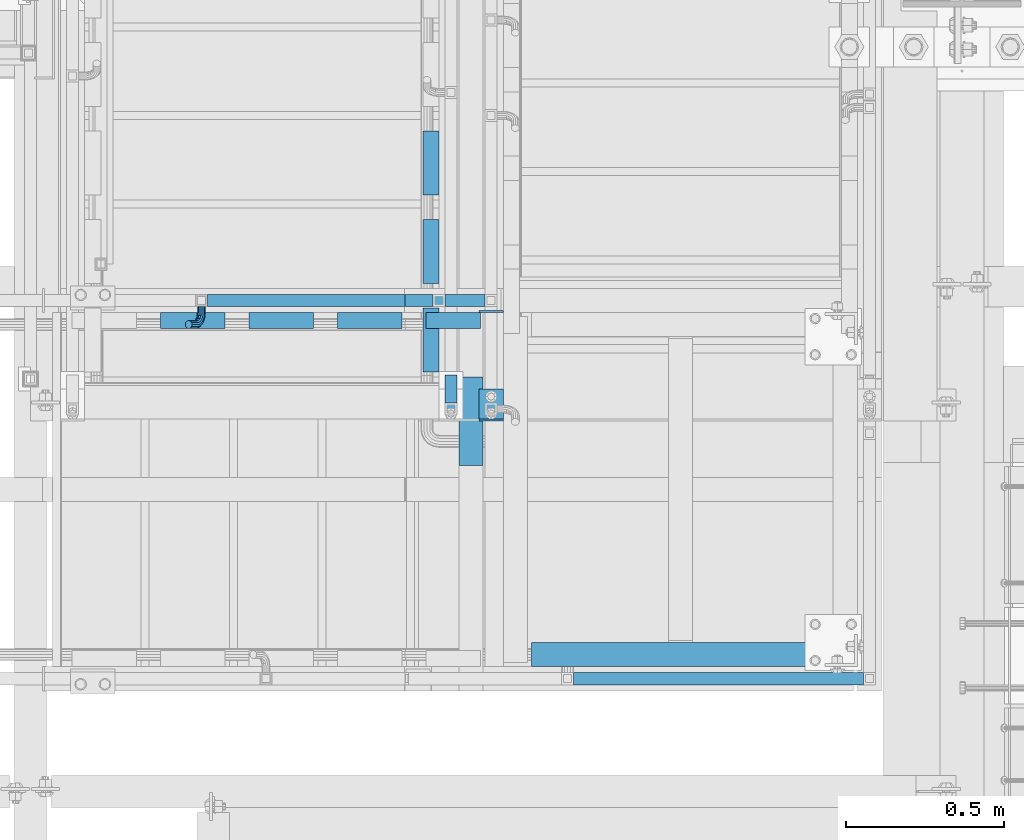
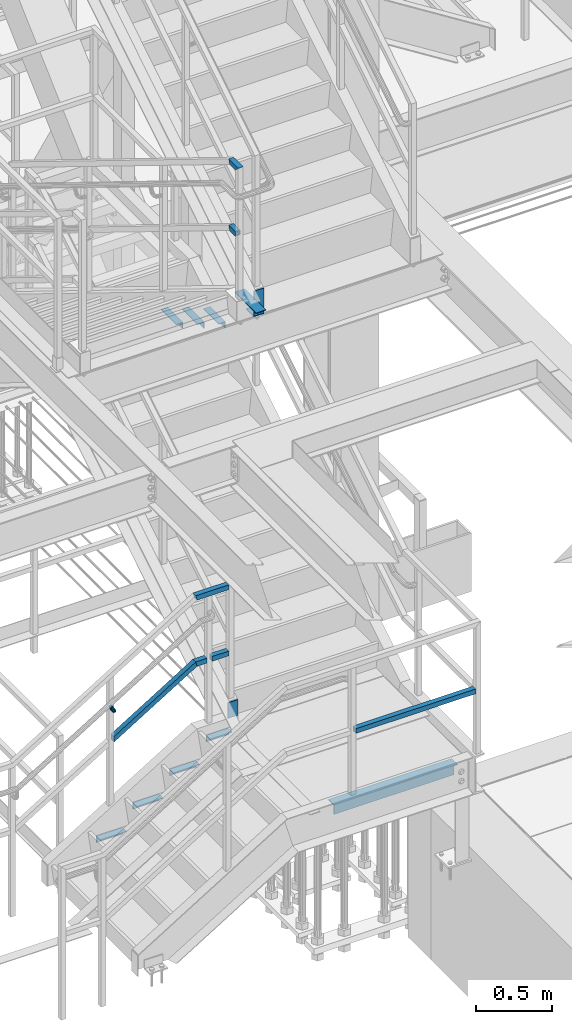
# One storey, part 2076 of 3843: 18 beams, 2 members, 8 elements without a shape of their own.
"""IFC2X3 building model written with IfcOpenShell, lengths in millimetres."""

from ifc_helpers import new_model, si_unit, frame, origin_with_axes, place, context, subcontext, project, spatial, faceted_brep, material, type_object, element, aggregate, save


model = new_model("IFC2X3")

# Units and contexts
model_context = context("Model", 3, precision=1e-05, world=origin_with_axes())
body_context = subcontext(model_context, "Body", "Model", "MODEL_VIEW")
ifc_project = project(units=[si_unit("LENGTHUNIT", "METRE", prefix="MILLI"), si_unit("AREAUNIT", "SQUARE_METRE"), si_unit("VOLUMEUNIT", "CUBIC_METRE"), si_unit("MASSUNIT", "GRAM", prefix="KILO"), si_unit("TIMEUNIT", "SECOND"), si_unit("PLANEANGLEUNIT", "RADIAN"), si_unit("SOLIDANGLEUNIT", "STERADIAN"), si_unit("THERMODYNAMICTEMPERATUREUNIT", "DEGREE_CELSIUS"), si_unit("LUMINOUSINTENSITYUNIT", "LUMEN")], contexts=[model_context])

# Site, building, storey
site_placement = place(None, origin_with_axes())
site = spatial("IfcSite", under=ifc_project, at=site_placement, CompositionType="ELEMENT")
building_placement = place(site_placement, origin_with_axes())
building = spatial("IfcBuilding", under=site, at=building_placement, Name="Undefined", CompositionType="ELEMENT")
storey_placement = place(building_placement, origin_with_axes())
storey = spatial("IfcBuildingStorey", under=building, at=storey_placement, Name="Undefined", CompositionType="ELEMENT", Elevation=0.0)

# Assembly, beams
assembly_1_placement = place(storey_placement, origin_with_axes())
assembly_1 = element("IfcElementAssembly", 1, at=assembly_1_placement, inside=storey, Name="RAIL", AssemblyPlace="NOTDEFINED", PredefinedType="RIGID_FRAME")
ifc_material_1 = material()
beam_type_1 = type_object("IfcBeamType", Name="HSS1-1/2X1-1/2X1/4", PredefinedType="NOTDEFINED")
beam_1_placement = place(assembly_1_placement, frame((54317.9, 18961.0999971442, 35483.7999969276), z_axis=(0.0, 0.0, 1.0), x_axis=(0.0, -1.0, 0.0)))
beam_1 = element("IfcBeam", 2, at=beam_1_placement, type_object=beam_type_1, material=ifc_material_1, Name="RAIL", ObjectType="HSS1-1/2X1-1/2X1/4", context=body_context, shape_type="Brep", body=[
    faceted_brep([(3.59463564452017, 12.6999993300014, -12.6999993299978), (3.59463564452017, -12.6999993300014, -12.6999993299978), (82.5500000532629, -12.6999993300014, -12.6999993299978), (82.5500000532629, 12.6999993300014, -12.6999993299978), (-3.59463560431323, -12.6999993300014, 12.6999993299978), (82.5500000532629, -12.6999993300014, 12.6999993299978), (-3.59463560431323, 12.6999993300014, 12.6999993299978), (82.5500000532629, 12.6999993300014, 12.6999993299978), (5.39195352466777, 19.0499992350015, -19.0499992350015), (-5.39195348444628, 19.0499992350015, 19.0499992350015), (82.5500000532629, 19.0499992350015, 19.0499992350015), (82.5500000532629, 19.0499992350015, -19.0499992350015), (-5.39195348444628, -19.0499992350015, 19.0499992350015), (82.5500000532629, -19.0499999999993, 19.0499992350015), (5.39195352466777, -19.0499992350015, -19.0499992350015), (82.5500000532629, -19.0499992350015, -19.0499992350015)], [[[0, 1, 2, 3]], [[1, 4, 5, 2]], [[4, 6, 7, 5]], [[6, 0, 3, 7]], [[8, 9, 10, 11]], [[9, 12, 13, 10]], [[12, 14, 15, 13]], [[14, 8, 11, 15]], [[13, 15, 11, 10], [5, 7, 3, 2]], [[14, 12, 9, 8], [6, 4, 1, 0]]]),
])
beam_2_placement = place(assembly_1_placement, frame((54317.9, 18859.4999999946, 36017.1999969276), z_axis=(0.0, 0.0, -1.0), x_axis=(0.0, 1.0, 0.0)))
beam_2 = element("IfcBeam", 3, at=beam_2_placement, type_object=beam_type_1, material=ifc_material_1, Name="RAIL", ObjectType="HSS1-1/2X1-1/2X1/4", context=body_context, shape_type="Brep", body=[
    faceted_brep([(-12.6999993309546, 12.6999993299978, -12.6999993299978), (-12.6999993309546, -12.6999993299978, -12.6999993299978), (105.194632755753, -12.6999993299978, -12.6999993299978), (105.194632755753, 12.6999993299978, -12.6999993299978), (12.6999993290483, -12.6999993299978, 12.6999993299978), (98.0053615143879, -12.6999993299978, 12.6999993299978), (12.6999993290483, 12.6999993299978, 12.6999993299978), (98.0053615143879, 12.6999993299978, 12.6999993299978), (-19.0499992359546, 19.0499992350015, -19.0499992350015), (19.0499992350015, 19.0499992350015, 19.0499992350015), (96.2080436361175, 19.0499992350015, 19.0499992350015), (106.991950634023, 19.0499992350015, -19.0499992350015), (19.0499992350015, -19.0499992350015, 19.0499992350015), (96.2080436361175, -19.0499992350015, 19.0499992350015), (-19.0499992359546, -19.0499992350015, -19.0499992350015), (106.991950634023, -19.0499992350015, -19.0499992350015)], [[[0, 1, 2, 3]], [[1, 4, 5, 2]], [[4, 6, 7, 5]], [[6, 0, 3, 7]], [[8, 9, 10, 11]], [[9, 12, 13, 10]], [[12, 14, 15, 13]], [[14, 8, 11, 15]], [[13, 15, 11, 10], [5, 7, 3, 2]], [[14, 12, 9, 8], [6, 4, 1, 0]]]),
])
aggregate(assembly_1, [beam_1, beam_2])

assembly_2_placement = place(storey_placement, origin_with_axes())
assembly_2 = element("IfcElementAssembly", 4, at=assembly_2_placement, inside=storey, Name="RAIL", AssemblyPlace="NOTDEFINED", PredefinedType="RIGID_FRAME")
beam_3_placement = place(assembly_2_placement, frame((54279.7999999953, 19202.4000001452, 31873.0923070972), z_axis=(0.0, 0.0, 1.0), x_axis=(-1.0, 0.0, 0.0)))
beam_3 = element("IfcBeam", 5, at=beam_3_placement, type_object=beam_type_1, material=ifc_material_1, Name="RAIL", ObjectType="HSS1-1/2X1-1/2X1/4", context=body_context, shape_type="Brep", body=[
    faceted_brep([(19.0499992350015, -19.0499992350015, -19.0499992350015), (19.0499992350015, -19.0499992350015, 19.0499992350015), (19.0499992350015, 19.0499992350015, 19.0499992350015), (19.0499992350015, 19.0499992350015, -19.0499992350015), (19.0499992350015, 12.6999993299978, 12.6999993299978), (19.0499992350015, -12.6999993299978, 12.6999993299978), (19.0499992350015, -12.6999993299978, -12.6999993299978), (19.0499992350015, 12.6999993299978, -12.6999993299978), (96.2080466457774, 19.0499992350015, -19.0499992350015), (96.2080466457774, -19.0499992350015, -19.0499992350015), (106.991953643679, -19.0499992350015, 19.0499992350015), (106.991953643679, 19.0499992350015, 19.0499992350015), (105.194635765409, -12.6999993300014, 12.6999993300014), (105.194635765409, 12.6999993300014, 12.6999993300014), (98.0053645240478, 12.6999993300014, -12.6999993300014), (98.0053645240478, -12.6999993300014, -12.6999993300014)], [[[0, 1, 2, 3], [4, 5, 6, 7]], [[8, 9, 0, 3]], [[9, 10, 1, 0]], [[10, 11, 2, 1]], [[11, 8, 3, 2]], [[10, 9, 8, 11], [12, 13, 14, 15]], [[13, 12, 5, 4]], [[14, 13, 4, 7]], [[15, 14, 7, 6]], [[12, 15, 6, 5]]]),
])
beam_4_placement = place(assembly_2_placement, frame((54444.9000000417, 19202.4000001452, 31873.0923070972), z_axis=(0.0, 0.0, 1.0), x_axis=(-1.0, 0.0, 0.0)))
beam_4 = element("IfcBeam", 6, at=beam_4_placement, type_object=beam_type_1, material=ifc_material_1, Name="RAIL", ObjectType="HSS1-1/2X1-1/2X1/4", context=body_context, shape_type="Brep", body=[
    faceted_brep([(19.0499992350015, -19.0499992350015, -19.0499992350015), (19.0499992350015, -19.0499992350015, 19.0499992350015), (19.0499992350015, 19.0499992350015, 19.0499992350015), (19.0499992350015, 19.0499992350015, -19.0499992350015), (19.0499992350015, 12.6999993299978, 12.6999993299978), (19.0499992350015, -12.6999993299978, 12.6999993299978), (19.0499992350015, -12.6999993299978, -12.6999993299978), (19.0499992350015, 12.6999993299978, -12.6999993299978), (146.049999950203, 19.0499992350015, -19.0499992350015), (146.049999950203, -19.0499992350015, -19.0499992350015), (146.049999950203, -19.0499992350015, 19.0499992350015), (146.049999950203, 19.0499992350015, 19.0499992350015), (146.049999950203, -12.6999993299978, 12.6999993299978), (146.049999950203, 12.6999993299978, 12.6999993299978), (146.049999950203, 12.6999993299978, -12.6999993299978), (146.049999950203, -12.6999993299978, -12.6999993299978)], [[[0, 1, 2, 3], [4, 5, 6, 7]], [[8, 9, 0, 3]], [[9, 10, 1, 0]], [[10, 11, 2, 1]], [[11, 8, 3, 2]], [[10, 9, 8, 11], [12, 13, 14, 15]], [[13, 12, 5, 4]], [[14, 13, 4, 7]], [[15, 14, 7, 6]], [[12, 15, 6, 5]]]),
])
beam_5_placement = place(assembly_2_placement, frame((54057.5499999936, 19202.4000001452, 32406.4923070972), z_axis=(0.0, 0.0, -1.0), x_axis=(1.0, 0.0, 0.0)))
beam_5 = element("IfcBeam", 7, at=beam_5_placement, type_object=beam_type_1, material=ifc_material_1, Name="RAIL", ObjectType="HSS1-1/2X1-1/2X1/4", context=body_context, shape_type="Brep", body=[
    faceted_brep([(368.300000006377, -19.0499998546729, 19.0499992350015), (368.300000006377, -19.0499992350015, -19.0499992350015), (368.300000006377, 19.0499992350015, -19.0499992350015), (368.300000006377, 19.0499992350015, 19.0499992350015), (368.300000006377, -12.6999993300014, 12.6999993300014), (368.300000006377, 12.6999993300014, 12.6999993300014), (368.300000006377, 12.6999993300014, -12.6999993300014), (368.300000006377, -12.6999993300014, -12.6999993300014), (115.258045902359, 19.0499992350015, -19.0499992350015), (126.041952911473, 19.0499992350015, 19.0499992350015), (115.258045902359, -19.0499992350015, -19.0499992350015), (126.041952911473, -19.0499992350015, 19.0499992350015), (117.0553637825, 12.6999993300014, -12.6999993300014), (124.24463503134, 12.6999993300014, 12.6999993300014), (124.24463503134, -12.6999993300014, 12.6999993300014), (117.0553637825, -12.6999993300014, -12.6999993300014)], [[[0, 1, 2, 3], [4, 5, 6, 7]], [[8, 9, 3, 2]], [[10, 8, 2, 1]], [[11, 10, 1, 0]], [[9, 11, 0, 3]], [[8, 10, 11, 9], [12, 13, 14, 15]], [[15, 14, 4, 7]], [[12, 15, 7, 6]], [[13, 12, 6, 5]], [[14, 13, 5, 4]]]),
])

# Assembly, beam
assembly_3_placement = place(storey_placement, origin_with_axes())
assembly_3 = element("IfcElementAssembly", 8, at=assembly_3_placement, inside=storey, Name="RAIL", AssemblyPlace="NOTDEFINED", PredefinedType="RIGID_FRAME")
beam_6_placement = place(assembly_3_placement, frame((55638.6999999959, 18008.6000001452, 31873.0923070972), z_axis=(0.0, 0.0, 1.0), x_axis=(-1.0, 0.0, 0.0)))
beam_6 = element("IfcBeam", 9, at=beam_6_placement, type_object=beam_type_1, material=ifc_material_1, Name="RAIL", ObjectType="HSS1-1/2X1-1/2X1/4", context=body_context, shape_type="Brep", body=[
    faceted_brep([(19.0499992350015, -19.0499992350015, 19.0499992350015), (19.0499992350015, -19.0499992350015, -19.0499992350015), (933.44999923501, -19.0499992350015, -19.0499992350015), (933.44999923501, -19.0499992350015, 19.0499992350015), (19.0499992350015, 19.0499992350015, 19.0499992350015), (19.0500015258804, 0.0, 19.0500000000029), (933.450000766672, 0.0, 19.0499992350015), (933.44999923501, 19.0499992350015, 19.0499992350015), (19.0499992350015, 19.0499992350015, -19.0499992350015), (933.44999923501, 19.0499992350015, -19.0499992350015), (19.0500015258804, 0.0, -19.0500000000029), (19.0499992350015, 12.6999993299978, -12.6999993299978), (19.0499992350015, 12.6999993299978, 12.6999993299978), (19.0500015258731, 0.0, 12.6999999999971), (19.0499992350015, -12.6999993299978, 12.6999993299978), (19.0499992350015, -12.6999993299978, -12.6999993299978), (19.0500015258731, 0.0, -12.6999999999971), (933.450000766672, 12.6999993300014, -12.6999993300014), (933.450000766672, 12.6999993300014, 12.6999993300014), (933.450000766672, 0.0, 12.6999993300014), (933.450000766672, -12.6999993300014, 12.6999993300014), (933.450000766672, -12.6999993300014, -12.6999993300014), (933.450000766672, 0.0, -12.6999993300014), (933.450000766672, 0.0, -19.0499992350015)], [[[0, 1, 2, 3]], [[4, 5, 0, 3, 6, 7]], [[8, 4, 7, 9]], [[10, 1, 0, 5, 4, 8], [11, 12, 13, 14, 15, 16]], [[12, 11, 17, 18]], [[14, 13, 12, 18, 19, 20]], [[15, 14, 20, 21]], [[11, 16, 15, 21, 22, 17]], [[6, 3, 2, 23, 9, 7], [21, 20, 19, 18, 17, 22]], [[1, 10, 8, 9, 23, 2]]]),
])
aggregate(assembly_3, [beam_6])

# Member
member_type_1 = type_object("IfcMemberType", Name="HSS1-1/2X1-1/2X1/4", PredefinedType="NOTDEFINED")
member_1_placement = place(assembly_2_placement, frame((53530.4999999921, 19202.4000001452, 31474.5076924425), z_axis=(-0.524097425775922, 0.0, 0.851658316635875), x_axis=(0.851658316635872, 0.0, 0.524097425775926)))
member_1 = element("IfcMember", 10, at=member_1_placement, type_object=member_type_1, material=ifc_material_1, Name="RAIL", ObjectType="HSS1-1/2X1-1/2X1/4", context=body_context, shape_type="Brep", body=[
    faceted_brep([(10.6450480494532, -19.0499992350015, -19.0499992349796), (34.091200960931, -19.0499992350015, 19.0499992349942), (34.091200960931, 19.0499992350015, 19.0499992349942), (10.6450480494532, 19.0499992350015, -19.0499992349796), (30.1835087105574, 12.6999993300014, 12.6999993299978), (30.1835087105574, -12.6999993300014, 12.6999993299978), (14.5527402998268, -12.6999993300014, -12.6999993299833), (14.5527402998268, 12.6999993300014, -12.6999993299833), (755.124308559934, 19.0499992350015, -19.0499992355765), (755.124308559934, -19.0499992350015, -19.0499992355765), (765.908215567957, -19.0499992350015, 19.0499992343646), (765.908215567957, 19.0499992350015, 19.0499992343646), (764.110897688006, -12.6999993300014, 12.6999993293718), (764.110897688006, 12.6999993300014, 12.6999993293718), (756.9216264399, 12.6999993300014, -12.699999330591), (756.9216264399, -12.6999993300014, -12.699999330591)], [[[0, 1, 2, 3], [4, 5, 6, 7]], [[8, 9, 0, 3]], [[9, 10, 1, 0]], [[10, 11, 2, 1]], [[11, 8, 3, 2]], [[10, 9, 8, 11], [12, 13, 14, 15]], [[13, 12, 5, 4]], [[14, 13, 4, 7]], [[15, 14, 7, 6]], [[12, 15, 6, 5]]]),
])

# Assembly, beams
assembly_4_placement = place(storey_placement, origin_with_axes())
assembly_4 = element("IfcElementAssembly", 11, at=assembly_4_placement, inside=storey, Name="STAIR", AssemblyPlace="NOTDEFINED", PredefinedType="RIGID_FRAME")
ifc_material_2 = material(Name="STEEL/A36")
beam_type_2 = type_object("IfcBeamType", PredefinedType="NOTDEFINED")
beam_7_placement = place(assembly_4_placement, frame((54444.8999999683, 18821.4000000073, 34813.875), z_axis=(-1.0, 0.0, 0.0), x_axis=(0.0, 1.0, 0.0)))
beam_7 = element("IfcBeam", 12, at=beam_7_placement, type_object=beam_type_2, material=ifc_material_2, Name="PLATE", context=body_context, shape_type="Brep", body=[
    faceted_brep([(0.0, 3.17500000000291, -38.0999999999985), (0.0, 3.17500000000291, 38.0999999999985), (101.60000000002, 3.17500000000291, 38.0999999999985), (101.60000000002, 3.17500000000291, -38.0999999999985), (0.0, -3.17500000000291, 38.0999999999985), (101.60000000002, -3.17500000000291, 38.0999999999985), (0.0, -3.17500000000291, -38.0999999999985), (101.60000000002, -3.17500000000291, -38.0999999999985)], [[[0, 1, 2, 3]], [[1, 4, 5, 2]], [[4, 6, 7, 5]], [[6, 0, 3, 7]], [[5, 7, 3, 2]], [[6, 4, 1, 0]]]),
])
beam_8_placement = place(assembly_4_placement, frame((54444.8999999698, 18824.5750000075, 35017.5960274493), z_axis=(1.0, 0.0, 0.0), x_axis=(0.0, 0.0, -1.0)))
beam_8 = element("IfcBeam", 13, at=beam_8_placement, type_object=beam_type_2, material=ifc_material_2, Name="PLATE", context=body_context, shape_type="Brep", body=[
    faceted_brep([(0.0, 3.17500000000291, -38.0999999999985), (0.0, 3.17500000000291, 38.0999999999985), (200.546025080155, 3.17499999999927, 38.0999999999985), (200.546025080155, 3.17499999999927, -38.0999999999985), (0.0, -3.17500000000291, 38.0999999999985), (200.546025080155, -3.17499999999927, 38.0999999999985), (0.0, -3.17500000000291, -38.0999999999985), (200.546025080155, -3.17499999999927, -38.0999999999985)], [[[0, 1, 2, 3]], [[1, 4, 5, 2]], [[4, 6, 7, 5]], [[6, 0, 3, 7]], [[5, 7, 3, 2]], [[6, 4, 1, 0]]]),
])
aggregate(assembly_4, [beam_7, beam_8])

# Assembly, beam
assembly_5_placement = place(storey_placement, origin_with_axes())
assembly_5 = element("IfcElementAssembly", 14, at=assembly_5_placement, inside=storey, Name="STAIR", AssemblyPlace="NOTDEFINED", PredefinedType="RIGID_FRAME")
beam_9_placement = place(assembly_5_placement, frame((54444.8999999809, 19167.475000064, 31492.1203218572), z_axis=(1.0, 0.0, 0.0), x_axis=(0.0, 0.0, -1.0)))
beam_9 = element("IfcBeam", 15, at=beam_9_placement, type_object=beam_type_2, material=ifc_material_2, Name="PLATE", context=body_context, shape_type="Brep", body=[
    faceted_brep([(0.0, 3.17500000000291, -38.0999999999985), (0.0, 3.17500000000291, 38.0999999999985), (127.028014793057, 3.17499999999927, 38.0999999999985), (127.028014793057, 3.17499999999927, -38.0999999999985), (0.0, -3.17500000000291, 38.0999999999985), (127.028014793057, -3.17499999999927, 38.0999999999985), (0.0, -3.17500000000291, -38.0999999999985), (127.028014793057, -3.17499999999927, -38.0999999999985)], [[[0, 1, 2, 3]], [[1, 4, 5, 2]], [[4, 6, 7, 5]], [[6, 0, 3, 7]], [[5, 7, 3, 2]], [[6, 4, 1, 0]]]),
])
aggregate(assembly_5, [beam_9])

assembly_6_placement = place(storey_placement, origin_with_axes())
assembly_6 = element("IfcElementAssembly", 16, at=assembly_6_placement, inside=storey, Name="STAIR", AssemblyPlace="NOTDEFINED", PredefinedType="RIGID_FRAME")
beam_type_3 = type_object("IfcBeamType", Name="L2X2X3/16", PredefinedType="NOTDEFINED")
beam_10_placement = place(assembly_6_placement, frame((54254.4000000364, 19178.9859969272, 34699.0865354517), z_axis=(-1.0, 0.0, 0.0), x_axis=(0.0, -1.0, 0.0)))
beam_10 = element("IfcBeam", 17, at=beam_10_placement, type_object=beam_type_3, material=ifc_material_2, Name="ANGLE", ObjectType="L2X2X3/16", context=body_context, shape_type="Brep", body=[
    faceted_brep([(0.0, 25.4000000000015, -25.4000000000015), (0.0, 25.4000000000015, 25.4000000000015), (203.199999999997, 25.4000000000015, 25.4000000000015), (203.199999999997, 25.4000000000015, -25.4000000000015), (0.0, 20.6375000000007, 25.4000000000015), (203.199999999997, 20.6375000000007, 25.4000000000015), (0.0, 20.6375000000007, -20.6375000000007), (203.199999999997, 20.6375000000007, -20.6375000000007), (0.0, -25.4000000000015, -20.6375000000007), (203.199999999997, -25.4000000000015, -20.6375000000007), (0.0, -25.4000000000015, -25.4000000000015), (203.199999999997, -25.4000000000015, -25.4000000000015)], [[[0, 1, 2, 3]], [[1, 4, 5, 2]], [[4, 6, 7, 5]], [[6, 8, 9, 7]], [[8, 10, 11, 9]], [[10, 0, 3, 11]], [[5, 7, 9, 11, 3, 2]], [[10, 8, 6, 4, 1, 0]]]),
])

assembly_7_placement = place(storey_placement, origin_with_axes())
assembly_7 = element("IfcElementAssembly", 18, at=assembly_7_placement, inside=storey, Name="STAIR", AssemblyPlace="NOTDEFINED", PredefinedType="RIGID_FRAME")
beam_11_placement = place(assembly_7_placement, frame((54239.7140030385, 19138.9000000623, 31263.4923070961), z_axis=(0.0, -1.0, 0.0), x_axis=(1.0, 0.0, 0.0)))
beam_11 = element("IfcBeam", 19, at=beam_11_placement, type_object=beam_type_3, material=ifc_material_2, Name="ANGLE", ObjectType="L2X2X3/16", context=body_context, shape_type="Brep", body=[
    faceted_brep([(0.0, 25.4000000000015, -25.4000000000015), (0.0, 25.4000000000015, 25.4000000000015), (171.449999999997, 25.4000000000015, 25.4000000000015), (171.449999999997, 25.4000000000015, -25.4000000000015), (0.0, 20.6375000000007, 25.4000000000015), (171.449999999997, 20.6375000000007, 25.4000000000015), (0.0, 20.6375000000007, -20.6375000000007), (171.449999999997, 20.6375000000007, -20.6375000000007), (0.0, -25.4000000000015, -20.6375000000007), (171.449999999997, -25.4000000000015, -20.6375000000007), (0.0, -25.4000000000015, -25.4000000000015), (171.449999999997, -25.4000000000015, -25.4000000000015)], [[[0, 1, 2, 3]], [[1, 4, 5, 2]], [[4, 6, 7, 5]], [[6, 8, 9, 7]], [[8, 10, 11, 9]], [[10, 0, 3, 11]], [[5, 7, 9, 11, 3, 2]], [[10, 8, 6, 4, 1, 0]]]),
])

# Beam
beam_12_placement = place(assembly_6_placement, frame((54254.4000000339, 19458.3859969301, 34527.1480740367), z_axis=(-1.0, 0.0, 0.0), x_axis=(0.0, -1.0, 0.0)))
beam_12 = element("IfcBeam", 20, at=beam_12_placement, type_object=beam_type_3, material=ifc_material_2, Name="ANGLE", ObjectType="L2X2X3/16", context=body_context, shape_type="Brep", body=[
    faceted_brep([(0.0, 25.4000000000015, -25.4000000000015), (0.0, 25.4000000000015, 25.4000000000015), (203.199999999997, 25.4000000000015, 25.4000000000015), (203.199999999997, 25.4000000000015, -25.4000000000015), (0.0, 20.6375000000007, 25.4000000000015), (203.199999999997, 20.6375000000007, 25.4000000000015), (0.0, 20.6375000000007, -20.6375000000007), (203.199999999997, 20.6375000000007, -20.6375000000007), (0.0, -25.4000000000015, -20.6375000000007), (203.199999999997, -25.4000000000015, -20.6375000000007), (0.0, -25.4000000000015, -25.4000000000015), (203.199999999997, -25.4000000000015, -25.4000000000015)], [[[0, 1, 2, 3]], [[1, 4, 5, 2]], [[4, 6, 7, 5]], [[6, 8, 9, 7]], [[8, 10, 11, 9]], [[10, 0, 3, 11]], [[5, 7, 9, 11, 3, 2]], [[10, 8, 6, 4, 1, 0]]]),
])

beam_13_placement = place(assembly_6_placement, frame((54254.4000000314, 19737.785996933, 34355.2096126217), z_axis=(-1.0, 0.0, 0.0), x_axis=(0.0, -1.0, 0.0)))
beam_13 = element("IfcBeam", 21, at=beam_13_placement, type_object=beam_type_3, material=ifc_material_2, Name="ANGLE", ObjectType="L2X2X3/16", context=body_context, shape_type="Brep", body=[
    faceted_brep([(0.0, 25.4000000000015, -25.4000000000015), (0.0, 25.4000000000015, 25.4000000000015), (203.199999999997, 25.4000000000015, 25.4000000000015), (203.199999999997, 25.4000000000015, -25.4000000000015), (0.0, 20.6375000000007, 25.4000000000015), (203.199999999997, 20.6375000000007, 25.4000000000015), (0.0, 20.6375000000007, -20.6375000000007), (203.199999999997, 20.6375000000007, -20.6375000000007), (0.0, -25.4000000000015, -20.6375000000007), (203.199999999997, -25.4000000000015, -20.6375000000007), (0.0, -25.4000000000015, -25.4000000000015), (203.199999999997, -25.4000000000015, -25.4000000000015)], [[[0, 1, 2, 3]], [[1, 4, 5, 2]], [[4, 6, 7, 5]], [[6, 8, 9, 7]], [[8, 10, 11, 9]], [[10, 0, 3, 11]], [[5, 7, 9, 11, 3, 2]], [[10, 8, 6, 4, 1, 0]]]),
])

aggregate(assembly_6, [beam_10, beam_12, beam_13])

beam_14_placement = place(assembly_7_placement, frame((53960.3140030364, 19138.9000000623, 31088.3788456777), z_axis=(0.0, -1.0, 0.0), x_axis=(1.0, 0.0, 0.0)))
beam_14 = element("IfcBeam", 22, at=beam_14_placement, type_object=beam_type_3, material=ifc_material_2, Name="ANGLE", ObjectType="L2X2X3/16", context=body_context, shape_type="Brep", body=[
    faceted_brep([(0.0, 25.4000000000015, -25.4000000000015), (0.0, 25.4000000000015, 25.4000000000015), (203.199999999997, 25.4000000000015, 25.4000000000015), (203.199999999997, 25.4000000000015, -25.4000000000015), (0.0, 20.6375000000007, 25.4000000000015), (203.199999999997, 20.6375000000007, 25.4000000000015), (0.0, 20.6375000000007, -20.6375000000007), (203.199999999997, 20.6375000000007, -20.6375000000007), (0.0, -25.4000000000015, -20.6375000000007), (203.199999999997, -25.4000000000015, -20.6375000000007), (0.0, -25.4000000000015, -25.4000000000015), (203.199999999997, -25.4000000000015, -25.4000000000015)], [[[0, 1, 2, 3]], [[1, 4, 5, 2]], [[4, 6, 7, 5]], [[6, 8, 9, 7]], [[8, 10, 11, 9]], [[10, 0, 3, 11]], [[5, 7, 9, 11, 3, 2]], [[10, 8, 6, 4, 1, 0]]]),
])

beam_15_placement = place(assembly_7_placement, frame((53680.9140030351, 19138.9000000623, 30916.4403842586), z_axis=(0.0, -1.0, 0.0), x_axis=(1.0, 0.0, 0.0)))
beam_15 = element("IfcBeam", 23, at=beam_15_placement, type_object=beam_type_3, material=ifc_material_2, Name="ANGLE", ObjectType="L2X2X3/16", context=body_context, shape_type="Brep", body=[
    faceted_brep([(0.0, 25.4000000000015, -25.4000000000015), (0.0, 25.4000000000015, 25.4000000000015), (203.199999999997, 25.4000000000015, 25.4000000000015), (203.199999999997, 25.4000000000015, -25.4000000000015), (0.0, 20.6375000000007, 25.4000000000015), (203.199999999997, 20.6375000000007, 25.4000000000015), (0.0, 20.6375000000007, -20.6375000000007), (203.199999999997, 20.6375000000007, -20.6375000000007), (0.0, -25.4000000000015, -20.6375000000007), (203.199999999997, -25.4000000000015, -20.6375000000007), (0.0, -25.4000000000015, -25.4000000000015), (203.199999999997, -25.4000000000015, -25.4000000000015)], [[[0, 1, 2, 3]], [[1, 4, 5, 2]], [[4, 6, 7, 5]], [[6, 8, 9, 7]], [[8, 10, 11, 9]], [[10, 0, 3, 11]], [[5, 7, 9, 11, 3, 2]], [[10, 8, 6, 4, 1, 0]]]),
])

beam_16_placement = place(assembly_7_placement, frame((53401.5140030339, 19138.9000000623, 30744.5019228396), z_axis=(0.0, -1.0, 0.0), x_axis=(1.0, 0.0, 0.0)))
beam_16 = element("IfcBeam", 24, at=beam_16_placement, type_object=beam_type_3, material=ifc_material_2, Name="ANGLE", ObjectType="L2X2X3/16", context=body_context, shape_type="Brep", body=[
    faceted_brep([(0.0, 25.4000000000015, -25.4000000000015), (0.0, 25.4000000000015, 25.4000000000015), (203.199999999997, 25.4000000000015, 25.4000000000015), (203.199999999997, 25.4000000000015, -25.4000000000015), (0.0, 20.6375000000007, 25.4000000000015), (203.199999999997, 20.6375000000007, 25.4000000000015), (0.0, 20.6375000000007, -20.6375000000007), (203.199999999997, 20.6375000000007, -20.6375000000007), (0.0, -25.4000000000015, -20.6375000000007), (203.199999999997, -25.4000000000015, -20.6375000000007), (0.0, -25.4000000000015, -25.4000000000015), (203.199999999997, -25.4000000000015, -25.4000000000015)], [[[0, 1, 2, 3]], [[1, 4, 5, 2]], [[4, 6, 7, 5]], [[6, 8, 9, 7]], [[8, 10, 11, 9]], [[10, 0, 3, 11]], [[5, 7, 9, 11, 3, 2]], [[10, 8, 6, 4, 1, 0]]]),
])

beam_type_4 = type_object("IfcBeamType", PredefinedType="NOTDEFINED")
beam_17_placement = place(assembly_2_placement, frame((53530.1081983989, 19183.3500001452, 31743.4259557099), z_axis=(-0.851658316635875, 0.0, -0.524097425775922), x_axis=(0.0, -1.0, 0.0)))
beam_17 = element("IfcBeam", 25, at=beam_17_placement, type_object=beam_type_4, material=ifc_material_2, Name="BRACKET ARM", context=body_context, shape_type="Brep", body=[
    faceted_brep([(0.0, -12.6999999999971, 0.0), (0.0, -10.9985226280696, -6.34999999999854), (19.0500015258731, -10.9985226280623, -6.34999999999854), (19.0500015258731, -12.6999999999971, -6.33008312433958e-10), (0.0, -6.35000000000582, -10.9985226280623), (19.0500015258731, -6.34999999999854, -10.9985226280623), (0.0, 0.0, -12.6999999999971), (19.0500015258731, 0.0, -12.6999999999971), (0.0, 6.35000000000582, -10.9985226280623), (19.0500015258731, 6.34999999999854, -10.9985226280623), (0.0, 10.9985226280696, -6.34999999999854), (19.0500015258731, 10.9985226280623, -6.34999999999854), (0.0, 12.6999999999971, 0.0), (19.0500015258731, 12.6999999999971, 0.0), (0.0, 10.9985226280696, 6.34999999999854), (19.0500015258731, 10.9985226280623, 6.34999999999854), (0.0, 6.35000000000582, 10.9985226280623), (19.0500015258731, 6.34999999999854, 10.9985226280623), (0.0, 0.0, 12.6999999999971), (19.0500015258731, 0.0, 12.6999999999971), (0.0, -6.35000000000582, 10.9985226280623), (19.0500015258731, -6.34999999999854, 10.9985226280623), (0.0, -10.9985226280696, 6.34999999999854), (19.0500015258731, -10.9985226280623, 6.34999999999854), (38.4903193060891, -8.8330803677236, -3.34694050252438e-10), (37.8391921052389, -7.26112024908798, 6.34999999974389), (36.0602795104642, -2.96644533684594, 10.9985226280041), (33.6302397149266, 2.90018969451194, 12.7000000002226), (31.2001999194181, 8.76682472604443, 10.9985226285644), (29.4212873247307, 13.061499638774, 6.35000000070431), (28.7701601240115, 14.6334597580644, 7.78527464717627e-10), (29.4212873248762, 13.0614996394288, -6.34999999929278), (31.2001999196509, 8.76682472718676, -10.9985226275603), (33.6302397151885, 2.90018969582889, -12.6999999997788), (36.0602795106824, -2.96644533571089, -10.9985226281206), (37.8391921053699, -7.26112024843314, -6.35000000026048), (53.7678987435793, 3.38210125690239, -6.3499999994383), (54.9710249311902, 2.17897506880399, 5.0931703299284e-10), (50.4808968708676, 6.66910312997061, -10.9985226273784), (45.9907688103704, 11.1592311906061, -12.6999999991458), (41.5006407498004, 15.6493592510378, -10.9985226270364), (38.213638876914, 18.9363611235749, -6.34999999884167), (37.0105126890558, 20.1394873109457, 1.20053300634027e-09), (38.2136388766667, 18.9363611228473, 6.35000000115542), (41.5006407493784, 15.6493592497718, 10.9985226290883), (45.9907688098756, 11.1592311891436, 12.7000000008557), (50.4808968704456, 6.66910312870459, 10.9985226287463), (53.7678987433319, 3.38210125617479, 6.35000000055879), (64.4111202489148, 19.3108078951118, -6.34999999821594), (65.9830803677178, 18.6596806939051, 1.77533365786076e-09), (60.1164453365491, 21.0897204901557, -10.9985226262725), (54.2498103051475, 23.5197602857806, -12.6999999981927), (48.3831752736587, 25.9498000811873, -10.9985226262434), (44.0885003610601, 27.7287126756128, -6.34999999817228), (42.516540241937, 28.3798398759754, 1.83354131877422e-09), (44.08850036074, 27.7287126747688, 6.35000000183209), (48.3831752731057, 25.9498000797321, 10.9985226298813), (54.2498103045073, 23.5197602840999, 12.7000000018088), (60.1164453359961, 21.0897204886933, 10.9985226298522), (64.4111202485947, 19.3108078942678, 6.35000000178115), (68.1485226282239, 38.0999984746086, -6.3499999967753), (69.8499999999913, 38.0999984741211, 2.92493496090174e-09), (63.500000000291, 38.0999984749651, -10.9985226249628), (57.1500000003434, 38.0999984750961, -12.6999999970722), (50.8000000002939, 38.0999984749651, -10.998522625312), (46.1514773720992, 38.0999984746086, -6.34999999737192), (44.4499999999971, 38.0999984741211, 2.58296495303512e-09), (46.1514773717645, 38.0999984736336, 6.35000000262517), (50.7999999996973, 38.0999984732771, 10.9985226308127), (57.1499999996449, 38.0999984731461, 12.700000002922), (63.4999999996944, 38.0999984732771, 10.9985226311619), (68.1485226278892, 38.0999984736336, 6.35000000322179), (68.1485226280638, 76.2000000002372, -6.34999999414867), (69.8499999999913, 76.199999999757, 5.84986992180347e-09), (63.5, 76.200000000601, -10.9985226222125), (57.1499999999942, 76.2000000007247, -12.6999999941472), (50.7999999999884, 76.200000000601, -10.9985226222125), (46.1514773719246, 76.2000000002372, -6.34999999414867), (44.4499999999971, 76.199999999757, 5.84986992180347e-09), (46.1514773719246, 76.1999999992695, 6.35000000584841), (50.7999999999884, 76.1999999989057, 10.9985226339122), (57.1499999999942, 76.199999998782, 12.700000005847), (63.5, 76.1999999989057, 10.9985226339122), (68.1485226280638, 76.1999999992695, 6.35000000584841)], [[[0, 1, 2, 3]], [[1, 4, 5, 2]], [[4, 6, 7, 5]], [[6, 8, 9, 7]], [[8, 10, 11, 9]], [[10, 12, 13, 11]], [[12, 14, 15, 13]], [[14, 16, 17, 15]], [[16, 18, 19, 17]], [[18, 20, 21, 19]], [[20, 22, 23, 21]], [[22, 0, 3, 23]], [[22, 20, 18, 16, 14, 12, 10, 8, 6, 4, 1, 0]], [[23, 3, 24, 25]], [[21, 23, 25, 26]], [[19, 21, 26, 27]], [[17, 19, 27, 28]], [[15, 17, 28, 29]], [[13, 15, 29, 30]], [[11, 13, 30, 31]], [[9, 11, 31, 32]], [[7, 9, 32, 33]], [[5, 7, 33, 34]], [[2, 5, 34, 35]], [[3, 2, 35, 24]], [[35, 36, 37, 24]], [[34, 38, 36, 35]], [[33, 39, 38, 34]], [[32, 40, 39, 33]], [[31, 41, 40, 32]], [[30, 42, 41, 31]], [[29, 43, 42, 30]], [[28, 44, 43, 29]], [[27, 45, 44, 28]], [[26, 46, 45, 27]], [[25, 47, 46, 26]], [[24, 37, 47, 25]], [[36, 48, 49, 37]], [[38, 50, 48, 36]], [[39, 51, 50, 38]], [[40, 52, 51, 39]], [[41, 53, 52, 40]], [[42, 54, 53, 41]], [[43, 55, 54, 42]], [[44, 56, 55, 43]], [[45, 57, 56, 44]], [[46, 58, 57, 45]], [[47, 59, 58, 46]], [[37, 49, 59, 47]], [[48, 60, 61, 49]], [[50, 62, 60, 48]], [[51, 63, 62, 50]], [[52, 64, 63, 51]], [[53, 65, 64, 52]], [[54, 66, 65, 53]], [[55, 67, 66, 54]], [[56, 68, 67, 55]], [[57, 69, 68, 56]], [[58, 70, 69, 57]], [[59, 71, 70, 58]], [[49, 61, 71, 59]], [[61, 60, 72, 73]], [[60, 62, 74, 72]], [[62, 63, 75, 74]], [[63, 64, 76, 75]], [[64, 65, 77, 76]], [[65, 66, 78, 77]], [[66, 67, 79, 78]], [[67, 68, 80, 79]], [[68, 69, 81, 80]], [[69, 70, 82, 81]], [[70, 71, 83, 82]], [[71, 61, 73, 83]], [[74, 75, 76, 77, 78, 79, 80, 81, 82, 83, 73, 72]]]),
])

aggregate(assembly_2, [beam_17, beam_3, member_1, beam_4, beam_5])

beam_type_5 = type_object("IfcBeamType", Name="L3X3X1/4", PredefinedType="NOTDEFINED")
beam_18_placement = place(assembly_7_placement, frame((55511.7, 18084.8000001452, 31250.7923070935), z_axis=(0.0, 1.0, 0.0), x_axis=(-1.0, 0.0, 0.0)))
beam_18 = element("IfcBeam", 26, at=beam_18_placement, type_object=beam_type_5, material=ifc_material_2, Name="ANGLE", ObjectType="L3X3X1/4", context=body_context, shape_type="Brep", body=[
    faceted_brep([(0.0, 31.75, -31.75), (0.0, 31.7500000838336, -38.0999999999985), (25.4000000505694, 31.7499999829743, -38.0999999999985), (25.4000000505694, 31.75, -31.75), (25.4000000793021, -38.0999999936466, -31.75), (25.4000000793021, -38.0999999999985, -38.0999999999985), (939.799999962997, -38.0999999999985, -38.0999999999985), (939.799999962997, -38.0999999999985, -31.75), (0.0, 38.0999999999985, -38.0999999999985), (939.800000000141, 38.0999999999985, -38.0999999999985), (0.0, 31.75, 38.0999999999985), (0.0, 38.0999999999985, 38.0999999999985), (25.4000000505694, 31.75, 38.0999999999985), (939.799999962997, 31.75, 38.0999999999985), (939.799999962997, 38.0999999999985, 38.0999999999985), (939.799999962997, 31.75, -31.75)], [[[0, 1, 2, 3]], [[4, 3, 2, 5]], [[6, 7, 4, 5]], [[1, 8, 9, 6, 5, 2]], [[10, 11, 8, 1, 0]], [[11, 10, 12, 13, 14]], [[8, 11, 14, 9]], [[13, 15, 7, 6, 9, 14]], [[12, 10, 0, 3, 15, 13]], [[7, 15, 3, 4]]]),
])

aggregate(assembly_7, [beam_18, beam_11, beam_14, beam_15, beam_16])

# Assembly, member
assembly_8_placement = place(storey_placement, origin_with_axes())
assembly_8 = element("IfcElementAssembly", 27, at=assembly_8_placement, inside=storey, Name="ref.", AssemblyPlace="NOTDEFINED", PredefinedType="RIGID_FRAME")
ifc_material_3 = material(Name="STEEL/Steel_Undefined")
member_type_2 = type_object("IfcMemberType", PredefinedType="NOTDEFINED")
member_2_placement = place(assembly_8_placement, frame((54381.4, 18961.1, 34947.2249969482), z_axis=(1.0, 0.0, 0.0), x_axis=(0.0, -1.0, 0.0)))
member_2 = element("IfcMember", 28, at=member_2_placement, type_object=member_type_2, material=ifc_material_3, Name="ref.", context=body_context, shape_type="Brep", body=[
    faceted_brep([(0.0, 3.17500000000291, -38.0999999999985), (0.0, 3.17500000000291, 38.0999999999985), (279.400000000001, 3.17500000000291, 38.0999999999985), (279.400000000001, 3.17500000000291, -38.0999999999985), (0.0, -3.17500000000291, 38.0999999999985), (279.400000000001, -3.17500000000291, 38.0999999999985), (0.0, -3.17500000000291, -38.0999999999985), (279.400000000001, -3.17500000000291, -38.0999999999985)], [[[0, 1, 2, 3]], [[1, 4, 5, 2]], [[4, 6, 7, 5]], [[6, 0, 3, 7]], [[5, 7, 3, 2]], [[6, 4, 1, 0]]]),
])
aggregate(assembly_8, [member_2])

save(model, "model.ifc")
